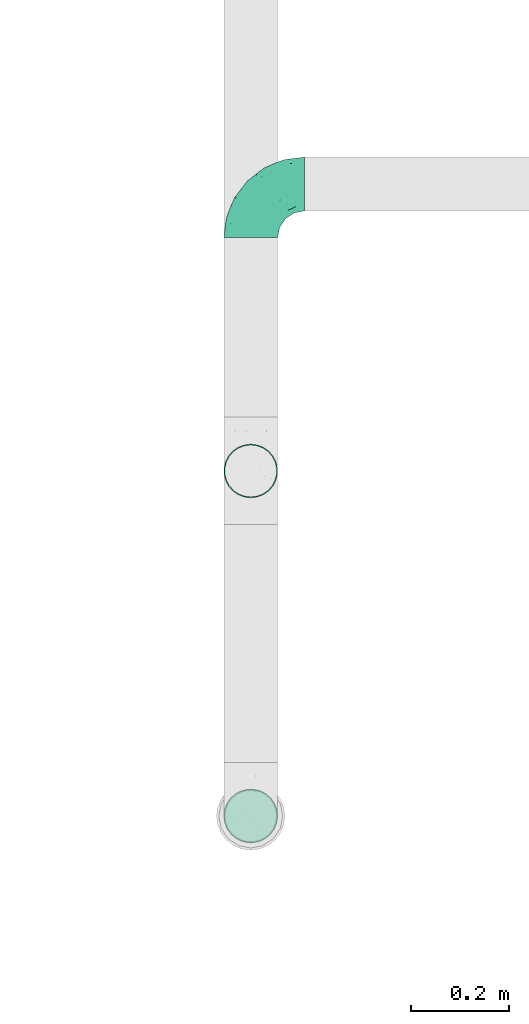
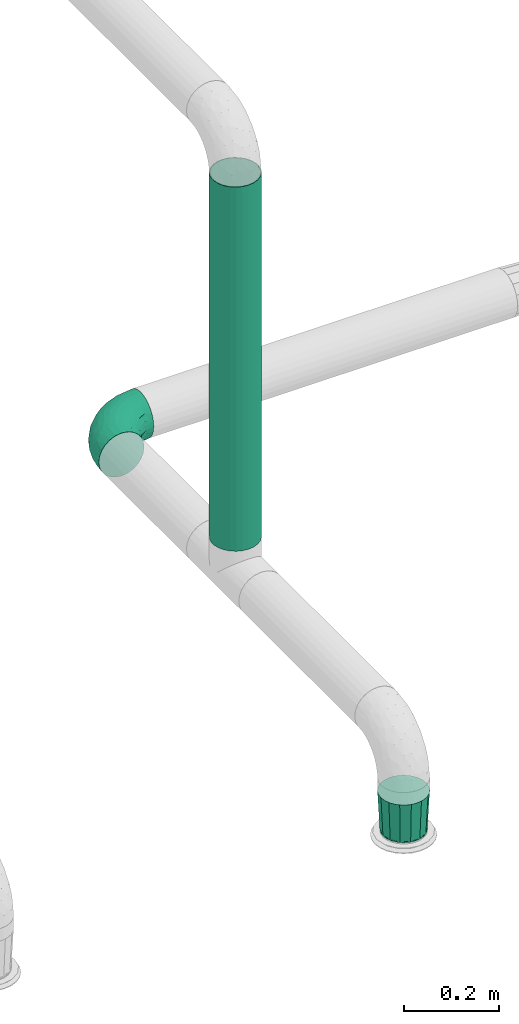
# One storey, part 97 of 103: 2 flow fittings, 1 flow segment.
"""IFC2X3 building model written with IfcOpenShell, lengths in millimetres."""

from ifc_helpers import new_model, entity, si_unit, converted_unit, derived_unit, direction, frame, origin_with_axes, origin_2d_with_axis, place, context, subcontext, project, spatial, hollow_circle, extrude, open_shell, surface_model, source, transform, mapped, material, layer, layer_set, layer_usage, type_object, element, save


model = new_model("IFC2X3")

# Units and contexts
model_context = context("Model", 3, precision=1e-05, world=origin_with_axes(), true_north=direction((0.0, 1.0)))
body_context = subcontext(model_context, "Body", "Model", "MODEL_VIEW")
ifc_project = project(units=[si_unit("AREAUNIT", "SQUARE_METRE"), si_unit("VOLUMEUNIT", "CUBIC_METRE", prefix="DECI"), si_unit("TIMEUNIT", "SECOND"), si_unit("THERMODYNAMICTEMPERATUREUNIT", "DEGREE_CELSIUS"), si_unit("PRESSUREUNIT", "PASCAL"), si_unit("MASSUNIT", "GRAM", prefix="KILO"), si_unit("LENGTHUNIT", "METRE", prefix="MILLI"), si_unit("POWERUNIT", "WATT"), si_unit("ELECTRICCURRENTUNIT", "AMPERE"), si_unit("ELECTRICVOLTAGEUNIT", "VOLT"), derived_unit("VOLUMETRICFLOWRATEUNIT", [(si_unit("VOLUMEUNIT", "CUBIC_METRE", prefix="DECI"), 1), (si_unit("TIMEUNIT", "SECOND"), -1)]), derived_unit("LINEARVELOCITYUNIT", [(si_unit("LENGTHUNIT", "METRE"), 1), (si_unit("TIMEUNIT", "SECOND"), -1)]), derived_unit("MASSDENSITYUNIT", [(si_unit("MASSUNIT", "GRAM", prefix="KILO"), 1), (si_unit("VOLUMEUNIT", "CUBIC_METRE"), -1)]), converted_unit("PLANEANGLEUNIT", "DEGREE", entity("IfcRatioMeasure", 0.01745), si_unit("PLANEANGLEUNIT", "RADIAN"), dimensions=[0, 0, 0, 0, 0, 0, 0])], contexts=[model_context])

# Site, building, storey
site_placement = place(None, origin_with_axes())
site = spatial("IfcSite", under=ifc_project, at=site_placement, CompositionType="ELEMENT")
building_placement = place(site_placement, origin_with_axes())
building = spatial("IfcBuilding", under=site, at=building_placement, Name="mc-building", CompositionType="ELEMENT")
storey_placement = place(building_placement, frame((0.0, 0.0, 5900.0), z_axis=(0.0, 0.0, 1.0), x_axis=(1.0, 0.0, 0.0)))
storey = spatial("IfcBuildingStorey", under=building, at=storey_placement, Name="3. Korrus", CompositionType="ELEMENT", Elevation=5900.0)

# Flow fittings
duct_fitting_type_1 = type_object("IfcDuctFittingType", Name="BU", PredefinedType="BEND")
shared_shape_1 = source(origin_with_axes(), body_context, "Body", "SurfaceModel", [
    surface_model("IfcShellBasedSurfaceModel", [(-110.0, 0.0, -55.0), (-110.0, -14.23505, -53.12592), (-110.0, 14.23505, -53.12592), (-110.0, 53.12592, 14.23505), (-110.0, 27.5, -47.63139), (-110.0, 38.89087, -38.89087), (-110.0, -55.0, 0.0), (-110.0, -53.12592, 14.23505), (-110.0, -38.89087, -38.89087), (-110.0, -27.5, -47.63139), (-110.0, -53.12592, -14.23505), (-110.0, -47.63139, -27.5), (-110.0, -14.23505, 53.12592), (-110.0, 14.23505, 53.12592), (-110.0, 27.5, 47.63139), (-110.0, -47.63139, 27.5), (-110.0, -38.89087, 38.89087), (-110.0, -27.5, 47.63139), (-110.0, 0.0, 55.0), (-110.0, 55.0, 0.0), (-110.0, 53.12592, -14.23505), (-110.0, 47.63139, -27.5), (-110.0, 47.63139, 27.5), (-110.0, 38.89087, 38.89087), (-14.23505, 110.0, -53.12592), (-55.0, 110.0, 0.0), (0.0, 110.0, -55.0), (-27.5, 110.0, -47.63139), (-38.89087, 110.0, -38.89087), (-47.63139, 110.0, -27.5), (38.89087, 110.0, -38.89087), (53.12592, 110.0, 14.23505), (27.5, 110.0, -47.63139), (14.23505, 110.0, -53.12592), (47.63139, 110.0, -27.5), (53.12592, 110.0, -14.23505), (55.0, 110.0, 0.0), (-53.12592, 110.0, -14.23505), (-53.12592, 110.0, 14.23505), (-47.63139, 110.0, 27.5), (-38.89087, 110.0, 38.89087), (-27.5, 110.0, 47.63139), (0.0, 110.0, 55.0), (-14.23505, 110.0, 53.12592), (38.89087, 110.0, 38.89087), (47.63139, 110.0, 27.5), (27.5, 110.0, 47.63139), (14.23505, 110.0, 53.12592), (-64.21732, 48.68956, 43.63444), (-76.6405, 38.18013, 45.55988), (-60.44912, 32.56953, 51.94617), (-76.00813, 5.38378, 55.0), (-90.15553, 11.94394, 54.09138), (-78.5998, 26.77405, 50.81338), (-70.18771, 18.55163, 54.03432), (-75.55424, 54.2118, 32.41257), (-93.27622, 45.77614, 33.48188), (-96.12334, 22.13664, 50.81337), (-21.00813, 45.34362, 55.0), (-18.36258, 70.48427, 54.04484), (-32.04182, 59.64019, 52.24446), (-63.88653, 74.77858, 17.99134), (-74.66383, 63.08407, 19.92123), (-63.60674, 66.07878, 29.97482), (-99.597, 52.72185, 18.52927), (-93.11138, 56.59448, 10.50359), (-98.21577, 57.34403, 0.0), (-53.42855, 92.60092, 21.04759), (-88.54852, 54.8376, 21.04759), (-11.86161, 90.23965, 54.10313), (-5.38378, 76.00813, 55.0), (-57.34403, 98.21577, 0.0), (-56.64619, 93.12774, 10.22088), (-45.34362, 21.00813, 55.0), (-44.60838, 44.60838, 52.13415), (-92.68484, 35.46673, 43.63443), (-22.25266, 95.40765, 50.81337), (-35.97783, 90.61597, 43.63443), (-43.70931, 69.58671, 44.47149), (-27.23711, 77.39884, 50.81337), (-57.2828, 79.3123, 24.9774), (-58.67786, 84.31125, 16.04456), (-82.93277, 60.36161, 12.91784), (-49.88337, 54.51816, 47.224), (-74.57753, 66.83759, 9.55742), (-45.35812, 94.97281, 33.48188), (-59.18663, 88.95241, 0.0), (-51.517, 78.6292, 33.48188), (-65.14788, 80.03077, 0.0), (-56.45322, 62.06476, 39.63545), (-88.95241, 59.18663, 0.0), (-71.10913, 71.10913, 0.0), (-80.03077, 65.14788, 0.0), (-94.9309, 45.36788, -33.48188), (-93.11358, 56.60141, -10.46614), (-99.64997, 52.79499, -18.30015), (-90.20425, 36.08686, -43.63443), (-79.99933, 46.56772, -37.92748), (-76.00813, 5.38378, -55.0), (-72.75364, 19.68651, -53.60527), (-45.34362, 21.00813, -55.0), (-21.91957, 65.12078, -53.85897), (-5.38378, 76.00813, -55.0), (-21.00813, 45.34362, -55.0), (-35.41876, 92.89265, -43.63443), (-91.10309, 11.02766, -54.21832), (-45.77614, 93.27622, -33.48188), (-90.50474, 23.21022, -50.81337), (-70.92854, 33.31794, -49.51754), (-78.52933, 63.35627, -11.73997), (-24.91508, 84.05606, -50.81337), (-88.78941, 54.74452, -21.04759), (-69.59921, 57.34866, -33.48187), (-73.36422, 62.46673, -22.94182), (-63.49062, 67.59111, -28.46929), (-56.59448, 93.11138, -10.50359), (-54.8376, 88.54852, -21.04759), (-54.10679, 75.85581, -32.31867), (-57.75956, 31.09612, -52.80882), (-52.72185, 99.597, -18.52927), (-12.62913, 89.46304, -53.99097), (-34.46825, 66.46123, -50.04329), (-43.9837, 43.9837, -52.42279), (-65.78527, 72.58348, -17.68796), (-70.34468, 43.65295, -44.21951), (-57.47001, 51.99467, -44.91465), (-60.72547, 82.29174, -12.88567), (-42.34915, 74.24548, -43.63444), (-57.25194, 63.5016, -38.08211), (-80.95344, 53.56991, -29.32027), (-52.32891, 4.55257, -54.0482), (32.52942, 47.13398, -30.48571), (14.88266, 20.92917, -33.7947), (14.95561, 36.05775, -42.26543), (30.24048, 70.09027, -41.7461), (19.3559, 65.35825, -48.00507), (-70.35075, -46.44478, -19.5952), (-47.13398, -32.52942, -30.48571), (-28.49299, -30.5778, -16.4009), (-4.55257, 52.32891, -54.0482), (-22.4954, 22.4954, -53.25347), (-75.47368, -11.22546, -52.60718), (-81.32209, -51.5606, -9.98467), (-80.81763, -41.84862, -32.14655), (-70.09027, -30.24048, -41.7461), (-36.05774, -14.95561, -42.26543), (-9.15831, -10.852, -27.8997), (-65.35825, -19.3559, -48.00507), (11.22546, 75.47368, -52.60718), (3.94376, 43.9333, -50.53315), (-13.39742, 13.39743, -48.13058), (-43.9333, -3.94376, -50.53315), (49.37776, 67.29486, 0.0), (41.8609, 47.82256, -9.92641), (50.20582, 74.51695, -9.9731), (18.93131, 11.7156, -17.56239), (-27.5, -32.89419, 0.0), (-1.23348, -12.25375, -12.18106), (41.84862, 80.81763, -32.14655), (35.70604, 41.31408, -20.38235), (46.44478, 70.35075, -19.5952), (32.89419, 27.5, 0.0), (6.67262, -6.67262, 0.0), (-67.29486, -49.37776, 0.0), (-50.36265, -42.95545, -9.51562), (-5.47251, 5.47251, -39.92906), (-70.35075, -46.44478, 19.5952), (-74.51695, -50.20582, 9.9731), (-41.31407, -35.70604, 20.38235), (-47.13398, -32.52942, 30.48571), (-80.81763, -41.84862, 32.14655), (-4.55257, 52.32891, 54.0482), (11.22546, 75.47368, 52.60718), (-43.9333, -3.94376, 50.53315), (-65.35825, -19.3559, 48.00507), (-36.05774, -14.95561, 42.26543), (-70.09027, -30.24048, 41.7461), (-11.7156, -18.93131, 17.56239), (30.5778, 28.49299, 16.4009), (12.25375, 1.23348, 12.18106), (51.5606, 81.32209, 9.98467), (42.95545, 50.36265, 9.51562), (-75.47368, -11.22546, 52.60718), (-52.32891, 4.55257, 54.0482), (3.94376, 43.9333, 50.53315), (-22.4954, 22.4954, 53.25347), (-13.39742, 13.39743, 48.13058), (10.852, 9.15831, 27.8997), (-20.92916, -14.88266, 33.79469), (-47.82256, -41.8609, 9.92641), (32.52942, 47.13398, 30.48571), (46.44478, 70.35075, 19.5952), (41.84862, 80.81763, 32.14655), (30.24048, 70.09027, 41.7461), (19.3559, 65.35825, 48.00507), (14.95561, 36.05775, 42.26543), (-5.47251, 5.47251, 39.92906)], [open_shell([[[0, 1, 2]], [[2, 3, 4]], [[4, 3, 5]], [[2, 6, 7]], [[8, 6, 9]], [[1, 9, 6]], [[10, 6, 11]], [[8, 11, 6]], [[6, 2, 1]], [[12, 13, 14]], [[15, 2, 7]], [[16, 17, 2]], [[2, 17, 12]], [[12, 18, 13]], [[19, 20, 3]], [[5, 3, 21]], [[20, 21, 3]], [[22, 3, 2]], [[23, 22, 2]], [[12, 14, 2]], [[2, 14, 23]], [[15, 16, 2]], [[24, 25, 26]], [[27, 25, 24]], [[25, 28, 29]], [[28, 25, 27]], [[30, 26, 31]], [[26, 30, 32]], [[32, 33, 26]], [[34, 31, 35]], [[31, 34, 30]], [[35, 31, 36]], [[29, 37, 25]], [[38, 39, 26]], [[39, 40, 26]], [[41, 42, 40]], [[42, 26, 40]], [[42, 41, 43]], [[26, 44, 45]], [[31, 26, 45]], [[26, 46, 44]], [[47, 46, 26]], [[42, 47, 26]], [[25, 38, 26]], [[48, 49, 50]], [[18, 51, 52]], [[53, 54, 50]], [[55, 56, 49]], [[56, 22, 23]], [[13, 57, 14]], [[58, 59, 60]], [[61, 62, 63]], [[3, 64, 65]], [[53, 52, 54]], [[3, 65, 66]], [[67, 39, 38]], [[56, 68, 64]], [[65, 64, 68]], [[69, 59, 70]], [[38, 71, 72]], [[73, 58, 74]], [[75, 49, 56]], [[76, 69, 43]], [[53, 57, 52]], [[77, 78, 79]], [[41, 76, 43]], [[43, 69, 42]], [[55, 68, 56]], [[23, 14, 75]], [[76, 77, 79]], [[80, 67, 81]], [[62, 82, 68]], [[60, 78, 83]], [[62, 84, 82]], [[85, 77, 40]], [[81, 67, 72]], [[86, 72, 71]], [[87, 85, 67]], [[61, 81, 88]], [[77, 41, 40]], [[78, 77, 87]], [[23, 75, 56]], [[83, 89, 48]], [[85, 40, 39]], [[62, 68, 55]], [[89, 87, 63]], [[83, 48, 50]], [[57, 75, 14]], [[49, 75, 53]], [[67, 85, 39]], [[87, 77, 85]], [[63, 62, 55]], [[89, 55, 48]], [[80, 63, 87]], [[66, 65, 90]], [[66, 19, 3]], [[84, 91, 92]], [[92, 90, 82]], [[65, 82, 90]], [[61, 84, 62]], [[92, 82, 84]], [[68, 82, 65]], [[3, 22, 64]], [[56, 64, 22]], [[38, 25, 71]], [[81, 72, 86]], [[38, 72, 67]], [[91, 61, 88]], [[80, 81, 61]], [[63, 80, 61]], [[67, 80, 87]], [[77, 76, 41]], [[79, 59, 69]], [[79, 69, 76]], [[42, 69, 70]], [[60, 59, 79]], [[58, 70, 59]], [[78, 60, 79]], [[58, 60, 74]], [[52, 57, 13]], [[75, 57, 53]], [[18, 52, 13]], [[52, 51, 54]], [[51, 73, 54]], [[50, 73, 74]], [[73, 50, 54]], [[50, 74, 83]], [[60, 83, 74]], [[89, 83, 78]], [[87, 89, 78]], [[55, 89, 63]], [[50, 49, 53]], [[55, 49, 48]], [[81, 86, 88]], [[91, 84, 61]], [[5, 21, 93]], [[90, 94, 66]], [[20, 94, 95]], [[96, 93, 97]], [[98, 99, 100]], [[96, 4, 5]], [[101, 102, 103]], [[28, 27, 104]], [[2, 105, 0]], [[104, 106, 28]], [[99, 105, 107]], [[108, 107, 96]], [[90, 109, 94]], [[107, 2, 4]], [[20, 66, 94]], [[27, 24, 110]], [[109, 111, 94]], [[112, 113, 114]], [[37, 115, 71]], [[116, 106, 117]], [[99, 118, 100]], [[116, 115, 119]], [[37, 119, 115]], [[24, 120, 110]], [[121, 110, 101]], [[119, 106, 116]], [[101, 110, 120]], [[122, 103, 100]], [[117, 123, 116]], [[124, 125, 108]], [[115, 116, 126]], [[106, 29, 28]], [[26, 102, 120]], [[127, 104, 110]], [[97, 124, 96]], [[125, 122, 118]], [[128, 127, 125]], [[96, 5, 93]], [[115, 126, 86]], [[117, 106, 127]], [[111, 113, 129]], [[95, 93, 21]], [[97, 129, 112]], [[110, 104, 27]], [[106, 104, 127]], [[96, 107, 4]], [[99, 107, 108]], [[99, 108, 118]], [[105, 99, 98]], [[112, 114, 128]], [[121, 125, 127]], [[20, 19, 66]], [[109, 90, 92]], [[94, 111, 95]], [[91, 123, 109]], [[129, 113, 112]], [[93, 95, 111]], [[21, 20, 95]], [[71, 115, 86]], [[71, 25, 37]], [[123, 91, 88]], [[126, 116, 123]], [[123, 88, 126]], [[86, 126, 88]], [[37, 29, 119]], [[106, 119, 29]], [[129, 93, 111]], [[124, 112, 125]], [[0, 105, 98]], [[107, 105, 2]], [[125, 118, 108]], [[100, 118, 122]], [[93, 129, 97]], [[113, 111, 109]], [[109, 123, 113]], [[114, 123, 117]], [[123, 114, 113]], [[128, 114, 117]], [[127, 128, 117]], [[112, 128, 125]], [[103, 122, 101]], [[110, 121, 127]], [[101, 122, 121]], [[125, 121, 122]], [[26, 120, 24]], [[101, 120, 102]], [[96, 124, 108]], [[92, 91, 109]], [[112, 124, 97]], [[100, 130, 98]], [[131, 132, 133]], [[32, 134, 135]], [[136, 137, 138]], [[139, 140, 103]], [[98, 141, 0]], [[142, 10, 136]], [[143, 144, 137]], [[6, 10, 142]], [[137, 145, 146]], [[144, 147, 145]], [[143, 136, 11]], [[11, 136, 10]], [[8, 143, 11]], [[148, 149, 139]], [[8, 9, 144]], [[9, 1, 147]], [[130, 141, 98]], [[103, 140, 100]], [[148, 135, 149]], [[150, 151, 140]], [[152, 153, 154]], [[130, 140, 151]], [[148, 26, 33]], [[147, 1, 141]], [[155, 146, 132]], [[156, 138, 157]], [[134, 30, 158]], [[150, 140, 149]], [[158, 30, 34]], [[30, 134, 32]], [[153, 159, 160]], [[131, 160, 159]], [[144, 145, 137]], [[36, 152, 154]], [[146, 138, 137]], [[155, 161, 162]], [[158, 160, 131]], [[133, 149, 135]], [[156, 163, 164]], [[163, 142, 164]], [[139, 103, 102]], [[153, 152, 161]], [[34, 35, 160]], [[162, 157, 155]], [[132, 165, 133]], [[157, 146, 155]], [[140, 130, 100]], [[141, 130, 151]], [[141, 151, 147]], [[141, 1, 0]], [[102, 26, 148]], [[140, 139, 149]], [[102, 148, 139]], [[135, 33, 32]], [[151, 150, 145]], [[9, 147, 144]], [[151, 145, 147]], [[145, 165, 146]], [[135, 148, 33]], [[133, 135, 134]], [[131, 133, 134]], [[133, 165, 150]], [[133, 150, 149]], [[145, 150, 165]], [[132, 131, 159]], [[146, 165, 132]], [[160, 158, 34]], [[134, 158, 131]], [[144, 143, 8]], [[136, 143, 137]], [[155, 153, 161]], [[154, 153, 160]], [[153, 155, 159]], [[132, 159, 155]], [[160, 35, 154]], [[36, 154, 35]], [[164, 136, 138]], [[6, 142, 163]], [[136, 164, 142]], [[156, 164, 138]], [[156, 157, 162]], [[146, 157, 138]], [[15, 7, 166]], [[6, 163, 167]], [[168, 169, 166]], [[166, 169, 170]], [[171, 172, 70]], [[173, 174, 175]], [[17, 176, 174]], [[177, 156, 162]], [[176, 16, 170]], [[170, 16, 15]], [[161, 178, 179]], [[152, 180, 181]], [[182, 173, 183]], [[18, 12, 182]], [[184, 185, 186]], [[183, 185, 73]], [[183, 73, 51]], [[177, 187, 188]], [[189, 168, 166]], [[187, 178, 190]], [[16, 176, 17]], [[161, 152, 181]], [[45, 191, 31]], [[45, 44, 192]], [[192, 191, 45]], [[180, 36, 31]], [[193, 194, 195]], [[46, 47, 194]], [[193, 195, 190]], [[193, 44, 46]], [[172, 42, 70]], [[185, 58, 73]], [[189, 163, 156]], [[163, 189, 167]], [[70, 58, 171]], [[184, 171, 185]], [[169, 188, 175]], [[180, 31, 191]], [[192, 193, 190]], [[191, 190, 178]], [[182, 174, 173]], [[194, 47, 172]], [[190, 195, 187]], [[186, 185, 173]], [[162, 179, 177]], [[188, 196, 175]], [[179, 187, 177]], [[185, 171, 58]], [[172, 171, 184]], [[172, 184, 194]], [[172, 47, 42]], [[51, 18, 182]], [[185, 183, 173]], [[51, 182, 183]], [[174, 12, 17]], [[184, 186, 195]], [[46, 194, 193]], [[184, 195, 194]], [[195, 196, 187]], [[174, 182, 12]], [[175, 174, 176]], [[169, 175, 176]], [[175, 196, 186]], [[175, 186, 173]], [[195, 186, 196]], [[188, 169, 168]], [[187, 196, 188]], [[166, 170, 15]], [[176, 170, 169]], [[193, 192, 44]], [[191, 192, 190]], [[177, 189, 156]], [[167, 189, 166]], [[189, 177, 168]], [[188, 168, 177]], [[166, 7, 167]], [[6, 167, 7]], [[181, 191, 178]], [[36, 180, 152]], [[191, 181, 180]], [[161, 181, 178]], [[161, 179, 162]], [[187, 179, 178]]])]),
])
flow_fitting_1_placement = place(storey_placement, frame((34114.97365, 9477.62755, 2345.0), z_axis=(0.0, 0.0, 1.0), x_axis=(-1.0, 0.0, 0.0)))
element("IfcFlowFitting", 1, at=flow_fitting_1_placement, inside=storey, type_object=duct_fitting_type_1, Name="BU", context=body_context, shape_type="MappedRepresentation", body=[
    mapped(shared_shape_1, transform((0.0, 0.0, 0.0), scale=1.0)),
])
duct_fitting_type_2 = type_object("IfcDuctFittingType", PredefinedType="TRANSITION")
shared_shape_2 = source(origin_with_axes(), body_context, "Body", "SurfaceModel", [
    surface_model("IfcShellBasedSurfaceModel", [(100.0, -55.0, 0.0), (100.0, -12.23865, 53.62104), (100.0, -34.29194, 43.00073), (100.0, 49.55329, 23.86361), (100.0, 34.29194, 43.00073), (100.0, 49.55329, -23.86361), (0.0, -45.04844, -21.69419), (0.0, -50.0, 0.0), (0.0, -45.04844, 21.69419), (0.0, 31.17449, 39.09157), (0.0, 45.04844, 21.69419), (0.0, 50.0, 0.0), (98.0, 47.63139, 27.5), (98.0, 0.0, 55.0), (98.0, 38.89087, 38.89087), (98.0, -38.89087, 38.89087), (98.0, -47.63139, 27.5), (100.0, 12.23865, 53.62104), (100.0, -49.55329, 23.86361), (100.0, 55.0, 0.0), (100.0, 12.23865, -53.62104), (100.0, 34.29194, -43.00073), (100.0, -49.55329, -23.86361), (100.0, -34.29194, -43.00073), (100.0, -12.23865, -53.62104), (0.0, -31.17449, 39.09157), (0.0, -11.12605, 48.7464), (0.0, 11.12605, 48.7464), (0.0, -31.17449, -39.09157), (0.0, 11.12605, -48.7464), (0.0, -11.12605, -48.7464), (0.0, 45.04844, -21.69419), (0.0, 31.17449, -39.09157), (0.0, 47.52422, -10.84709), (0.0, 38.11147, -30.39288), (100.0, 41.92261, -33.43217), (100.0, -41.92261, -33.43217), (0.0, -38.11147, -30.39288), (100.0, 23.2653, -48.31088), (0.0, 21.15027, -43.91899), (100.0, 52.32388, -11.72483), (0.0, 0.0, -48.7464), (100.0, 0.0, -53.62104), (0.0, -21.15027, -43.91899), (100.0, -23.2653, -48.31088), (0.0, -47.52422, -10.84709), (100.0, -52.32388, -11.72483), (0.0, -47.52422, 10.84709), (0.0, -38.11147, 30.39288), (100.0, -41.92261, 33.43217), (100.0, 41.92261, 33.43217), (0.0, 38.11147, 30.39288), (100.0, -23.2653, 48.31088), (0.0, -21.15027, 43.91899), (100.0, -52.32388, 11.72483), (0.0, 0.0, 48.7464), (100.0, 0.0, 53.62104), (0.0, 21.15027, 43.91899), (100.0, 23.2653, 48.31088), (0.0, 47.52422, 10.84709), (100.0, 52.32388, 11.72483), (100.0, -14.23505, -53.12592), (100.0, 0.0, -55.0), (100.0, -27.5, -47.63139), (100.0, 27.5, -47.63139), (100.0, -38.89087, -38.89087), (100.0, -53.12592, -14.23505), (100.0, -47.63139, -27.5), (100.0, -47.63139, 27.5), (100.0, 14.23505, -53.12592), (100.0, 38.89087, -38.89087), (100.0, 47.63139, -27.5), (100.0, 47.63139, 27.5), (100.0, 53.12592, -14.23505), (100.0, -53.12592, 14.23505), (100.0, -38.89087, 38.89087), (100.0, -27.5, 47.63139), (100.0, 0.0, 55.0), (100.0, -14.23505, 53.12592), (100.0, 53.12592, 14.23505), (100.0, 38.89087, 38.89087), (100.0, 27.5, 47.63139), (100.0, 14.23505, 53.12592), (98.0, -27.5, 47.63139), (98.0, -14.23505, 53.12592), (98.0, -53.12592, -14.23505), (98.0, 14.23505, 53.12592), (98.0, 27.5, 47.63139), (98.0, 53.12592, 14.23505), (98.0, 55.0, 0.0), (98.0, -47.63139, -27.5), (98.0, -53.12592, 14.23505), (98.0, 27.5, -47.63139), (98.0, -27.5, -47.63139), (98.0, -38.89087, -38.89087), (98.0, 0.0, -55.0), (98.0, -14.23505, -53.12592), (98.0, 38.89087, -38.89087), (98.0, 47.63139, -27.5), (98.0, 53.12592, -14.23505), (98.0, 14.23505, -53.12592), (98.0, -55.0, 0.0), (0.0, 0.0, 50.0), (0.0, 35.35534, 35.35534), (0.0, -12.94095, 48.29629), (0.0, -25.0, 43.30127), (0.0, -35.35534, 35.35534), (0.0, -48.29629, 12.94095), (0.0, -43.30127, 25.0), (0.0, 25.0, 43.30127), (0.0, 12.94095, 48.29629), (0.0, 43.30127, 25.0), (0.0, 48.29629, 12.94095), (0.0, 25.0, -43.30127), (0.0, 48.29629, -12.94095), (0.0, -48.29629, -12.94095), (0.0, -43.30127, -25.0), (0.0, -12.94095, -48.29629), (0.0, -25.0, -43.30127), (0.0, -35.35534, -35.35534), (0.0, 43.30127, -25.0), (0.0, 35.35534, -35.35534), (0.0, 12.94095, -48.29629), (0.0, 0.0, -50.0), (2.0, -35.35534, -35.35534), (2.0, -25.0, -43.30127), (2.0, -12.94095, -48.29629), (2.0, -43.30127, -25.0), (2.0, 0.0, -50.0), (2.0, -48.29629, -12.94095), (2.0, -50.0, 0.0), (2.0, 12.94095, -48.29629), (2.0, 25.0, -43.30127), (2.0, 43.30127, -25.0), (2.0, 48.29629, -12.94095), (2.0, 35.35534, -35.35534), (2.0, -48.29629, 12.94095), (2.0, -35.35534, 35.35534), (2.0, -43.30127, 25.0), (2.0, 35.35534, 35.35534), (2.0, -12.94095, 48.29629), (2.0, -25.0, 43.30127), (2.0, 0.0, 50.0), (2.0, 43.30127, 25.0), (2.0, 48.29629, 12.94095), (2.0, 50.0, 0.0), (2.0, 25.0, 43.30127), (2.0, 12.94095, 48.29629)], [open_shell([[[0, 1, 2]], [[3, 4, 5]], [[6, 7, 8]], [[9, 10, 11]], [[12, 13, 14]], [[15, 13, 16]], [[0, 4, 17]], [[2, 18, 0]], [[1, 0, 17]], [[3, 5, 19]], [[20, 21, 5]], [[22, 20, 5]], [[22, 5, 0]], [[22, 23, 24]], [[22, 24, 20]], [[4, 0, 5]], [[8, 25, 6]], [[6, 25, 26]], [[6, 26, 27]], [[11, 27, 9]], [[28, 6, 29]], [[30, 28, 29]], [[31, 6, 11]], [[31, 32, 29]], [[31, 29, 6]], [[27, 11, 6]], [[31, 33, 5]], [[34, 35, 32]], [[36, 22, 6]], [[36, 37, 23]], [[38, 29, 39]], [[33, 40, 5]], [[33, 11, 40]], [[19, 40, 11]], [[32, 21, 39]], [[32, 35, 21]], [[34, 31, 35]], [[30, 41, 42]], [[28, 43, 44]], [[42, 41, 20]], [[7, 45, 46]], [[38, 39, 21]], [[46, 0, 7]], [[6, 37, 36]], [[38, 20, 29]], [[43, 30, 24]], [[42, 24, 30]], [[28, 23, 37]], [[6, 22, 45]], [[35, 31, 5]], [[44, 43, 24]], [[20, 41, 29]], [[46, 45, 22]], [[44, 23, 28]], [[8, 47, 18]], [[48, 49, 25]], [[50, 3, 10]], [[50, 51, 4]], [[52, 26, 53]], [[47, 54, 18]], [[47, 7, 54]], [[0, 54, 7]], [[25, 2, 53]], [[25, 49, 2]], [[48, 8, 49]], [[27, 55, 56]], [[9, 57, 58]], [[56, 55, 1]], [[11, 59, 60]], [[52, 53, 2]], [[60, 19, 11]], [[10, 51, 50]], [[52, 1, 26]], [[57, 27, 17]], [[56, 17, 27]], [[9, 4, 51]], [[10, 3, 59]], [[49, 8, 18]], [[58, 57, 17]], [[1, 55, 26]], [[60, 59, 3]], [[58, 4, 9]], [[61, 62, 63]], [[63, 64, 65]], [[66, 67, 68]], [[65, 64, 67]], [[67, 64, 68]], [[69, 64, 62]], [[64, 63, 62]], [[70, 71, 64]], [[72, 64, 71]], [[71, 73, 19]], [[74, 0, 66]], [[72, 68, 64]], [[75, 68, 76]], [[77, 78, 76]], [[72, 76, 68]], [[76, 72, 77]], [[79, 72, 19]], [[19, 72, 71]], [[80, 81, 77]], [[77, 72, 80]], [[82, 77, 81]], [[74, 66, 68]], [[83, 84, 13]], [[15, 83, 13]], [[12, 16, 13]], [[16, 12, 85]], [[86, 87, 13]], [[87, 14, 13]], [[88, 89, 12]], [[89, 90, 12]], [[91, 16, 85]], [[90, 85, 12]], [[89, 92, 90]], [[93, 94, 95]], [[95, 94, 90]], [[96, 93, 95]], [[97, 92, 98]], [[98, 89, 99]], [[100, 95, 92]], [[92, 89, 98]], [[90, 92, 95]], [[101, 91, 85]], [[89, 73, 99]], [[99, 71, 98]], [[92, 97, 64]], [[70, 97, 98]], [[100, 92, 69]], [[73, 71, 99]], [[89, 19, 73]], [[92, 64, 69]], [[64, 97, 70]], [[98, 71, 70]], [[100, 69, 62]], [[62, 95, 100]], [[95, 61, 96]], [[96, 63, 93]], [[90, 94, 67]], [[65, 94, 93]], [[85, 90, 66]], [[63, 65, 93]], [[96, 61, 63]], [[85, 66, 0]], [[66, 90, 67]], [[94, 65, 67]], [[85, 0, 101]], [[62, 61, 95]], [[101, 74, 91]], [[91, 68, 16]], [[83, 15, 76]], [[75, 15, 16]], [[84, 83, 78]], [[74, 68, 91]], [[101, 0, 74]], [[83, 76, 78]], [[76, 15, 75]], [[16, 68, 75]], [[84, 78, 77]], [[77, 13, 84]], [[13, 82, 86]], [[86, 81, 87]], [[12, 14, 72]], [[80, 14, 87]], [[88, 12, 79]], [[81, 80, 87]], [[86, 82, 81]], [[88, 79, 19]], [[79, 12, 72]], [[14, 80, 72]], [[88, 19, 89]], [[77, 82, 13]], [[102, 103, 104]], [[105, 104, 106]], [[107, 108, 106]], [[103, 106, 104]], [[106, 103, 107]], [[109, 103, 110]], [[103, 102, 110]], [[111, 112, 103]], [[113, 103, 112]], [[112, 11, 114]], [[107, 103, 113]], [[113, 115, 107]], [[116, 115, 117]], [[117, 118, 119]], [[116, 117, 119]], [[117, 115, 113]], [[120, 121, 114]], [[113, 114, 121]], [[113, 122, 117]], [[113, 112, 114]], [[117, 122, 123]], [[7, 107, 115]], [[124, 125, 126]], [[127, 124, 126]], [[128, 129, 126]], [[127, 126, 129]], [[130, 129, 128]], [[131, 132, 128]], [[132, 130, 128]], [[133, 134, 135]], [[132, 135, 134]], [[132, 134, 130]], [[134, 136, 130]], [[137, 138, 136]], [[137, 136, 139]], [[140, 137, 139]], [[141, 137, 140]], [[142, 140, 139]], [[143, 139, 144]], [[144, 134, 145]], [[146, 147, 139]], [[139, 136, 144]], [[139, 147, 142]], [[136, 134, 144]], [[11, 134, 114]], [[114, 133, 120]], [[113, 121, 132]], [[135, 121, 120]], [[122, 113, 131]], [[134, 133, 114]], [[11, 145, 134]], [[113, 132, 131]], [[132, 121, 135]], [[120, 133, 135]], [[122, 131, 128]], [[128, 123, 122]], [[123, 126, 117]], [[117, 125, 118]], [[116, 119, 127]], [[124, 119, 118]], [[115, 116, 129]], [[125, 124, 118]], [[117, 126, 125]], [[115, 129, 130]], [[129, 116, 127]], [[119, 124, 127]], [[115, 130, 7]], [[128, 126, 123]], [[7, 136, 107]], [[107, 138, 108]], [[105, 106, 141]], [[137, 106, 108]], [[104, 105, 140]], [[136, 138, 107]], [[7, 130, 136]], [[105, 141, 140]], [[141, 106, 137]], [[108, 138, 137]], [[104, 140, 142]], [[142, 102, 104]], [[102, 147, 110]], [[110, 146, 109]], [[111, 103, 143]], [[139, 103, 109]], [[112, 111, 144]], [[146, 139, 109]], [[110, 147, 146]], [[112, 144, 145]], [[144, 111, 143]], [[103, 139, 143]], [[112, 145, 11]], [[142, 147, 102]]])]),
])
flow_fitting_2_placement = place(storey_placement, frame((34114.97365, 8183.57591, 2103.1), z_axis=(0.0, 1.0, 0.0), x_axis=(0.0, 0.0, 1.0)))
element("IfcFlowFitting", 2, at=flow_fitting_2_placement, inside=storey, type_object=duct_fitting_type_2, context=body_context, shape_type="MappedRepresentation", body=[
    mapped(shared_shape_2, transform((0.0, 0.0, 0.0), scale=1.0)),
])

# Flow segment
ifc_material = material(Name="FZ1")
ifc_layer = layer(ifc_material, 0.0)
ifc_layer_set = layer_set([ifc_layer], Name="FZ1")
ifc_layer_usage = layer_usage(ifc_layer_set, "AXIS1", "POSITIVE", 0.0)
duct_segment_type = type_object("IfcDuctSegmentType", PredefinedType="RIGIDSEGMENT")
shared_shape_3 = source(origin_with_axes(), body_context, "Body", "SweptSolid", [
    extrude(hollow_circle(Radius=55.0, WallThickness=2.0, at=origin_2d_with_axis()), frame((0.0, 0.0, 0.0), z_axis=(1.0, 0.0, 0.0), x_axis=(0.0, 1.0, 0.0)), (0.0, 0.0, 1.0), 933.0),
])
flow_segment_placement = place(storey_placement, frame((34114.97365, 8890.09332, 2425.0), z_axis=(-1.0, 0.0, 0.0), x_axis=(0.0, 0.0, 1.0)))
element("IfcFlowSegment", 3, at=flow_segment_placement, inside=storey, type_object=duct_segment_type, material=ifc_layer_usage, context=body_context, shape_type="MappedRepresentation", body=[
    mapped(shared_shape_3, transform((0.0, 0.0, 0.0), scale=1.0)),
])

save(model, "model.ifc")
